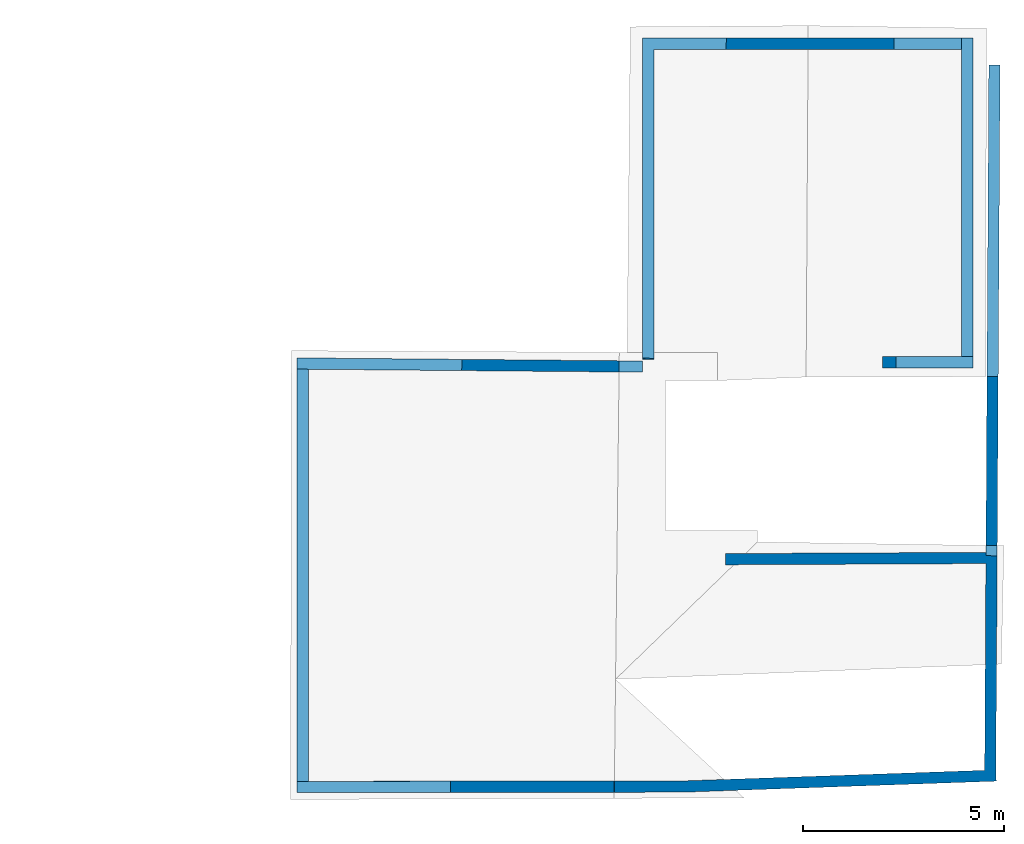
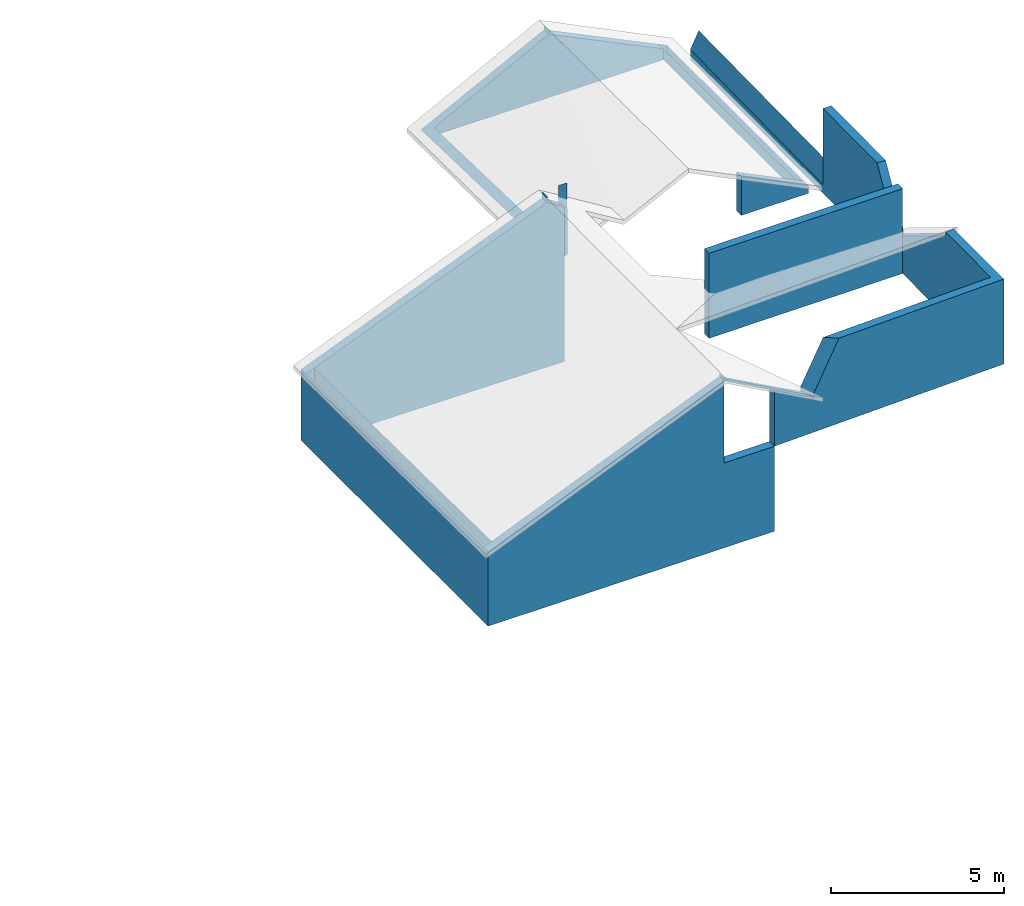
# One storey, part 4 of 4: 1 wall.
"""IFC4 building model written with IfcOpenShell, lengths in metres."""

from ifc_helpers import new_model, entity, si_unit, converted_unit, frame, frame_2d, origin_with_axes, place, context, subcontext, project, spatial, polygons, element, save


model = new_model("IFC4")

# Units and contexts
model_context = context("Model", 3, precision=1e-05, world=origin_with_axes())
plan_context = context("Plan", 2, precision=1e-05, world=frame_2d((0.0, 0.0, 0.0), x_axis=(1.0, 0.0, 0.0)))
body_context = subcontext(model_context, "Body", "Model", "MODEL_VIEW")
ifc_project = project(units=[converted_unit("PLANEANGLEUNIT", "degree", entity("IfcReal", 0.0174532925199433), si_unit("PLANEANGLEUNIT", "RADIAN"), dimensions=[0, 0, 0, 0, 0, 0, 0]), si_unit("AREAUNIT", "SQUARE_METRE"), si_unit("VOLUMEUNIT", "CUBIC_METRE"), si_unit("LENGTHUNIT", "METRE")], contexts=[model_context, plan_context])

# Site, building, storey
site_placement = place(None, origin_with_axes())
site = spatial("IfcSite", under=ifc_project, at=site_placement)
building_placement = place(site_placement, origin_with_axes())
building = spatial("IfcBuilding", under=site, at=building_placement, Name="Building")
storey_placement = place(building_placement, frame((0.0, 0.0, 3.0), z_axis=(0.0, 0.0, 1.0), x_axis=(1.0, 0.0, 0.0)))
storey = spatial("IfcBuildingStorey", under=building, at=storey_placement, Name="Dachgeschoss")

# Wall
wall_placement = place(storey_placement, frame((217.804901123047, 19.0355453491211, -2.38418579989741e-07), z_axis=(0.0, 0.0, 1.0), x_axis=(-0.00592900207266212, -0.999982416629791, 0.0)))
element("IfcWall", 1, at=wall_placement, inside=storey, Name="Wall", PredefinedType="ELEMENTEDWALL", context=body_context, shape_type="Tessellation", body=[
    polygons([(0.0, 0.280000001192093, 0.0), (17.5594806671143, 0.280000001192093, 3.0), (17.5594806671143, 0.280000001192093, 0.0), (0.00166013569105417, 0.0, 0.0), (17.5594806671143, 0.0, 3.0), (17.5594806671143, 0.0, 0.0), (12.1345434188843, 7.62939453125e-06, 0.0), (12.1345434188843, 7.62939453125e-06, 3.0), (12.4145278930664, 0.00297598727047443, 3.0), (12.4145278930664, 0.00297598727047443, 0.0), (12.4832715988159, -6.4811224937439, 3.0), (12.4832715988159, -6.4811224937439, 0.0), (12.2032871246338, -6.48409080505371, 3.0), (12.2032871246338, -6.48409080505371, 0.0), (7.55921268463135, -2.6036376953125, 0.0), (7.27921772003174, -2.60529780387878, 0.0), (7.26588344573975, -0.356342554092407, 0.0), (7.54587841033936, -0.354682445526123, 0.0), (-0.661626815795898, -0.683349609375, 0.0), (-0.663286864757538, -0.403354525566101, 0.0), (7.26588487625122, -0.356342911720276, 0.0), (7.26754474639893, -0.636337995529175, 0.0), (18.1491012573242, -7.52742004394531, 0.0), (17.8693370819092, -7.53891849517822, 0.0), (17.8063201904297, -6.00570869445801, 0.0), (18.0860843658447, -5.99420976638794, 0.0), (7.42261981964111, -8.56973266601562, 0.0), (7.70261859893799, -8.57056045532227, 0.0), (7.70088958740234, -9.15579032897949, 3.0), (7.70088958740234, -9.15579032897949, 0.0), (7.42089033126831, -9.15496253967285, 3.0), (7.42089033126831, -9.15496253967285, 0.0), (18.0860862731934, -5.99420928955078, 0.0), (17.8063220977783, -6.00570774078369, 0.0), (17.5479736328125, 0.280002593994141, 3.0), (17.5479736328125, 0.280002593994141, 0.0), (17.8277378082275, 0.291501045227051, 3.0), (17.8277378082275, 0.291501045227051, 0.0), (7.39721012115479, -17.1688270568848, -2.99999976158142), (7.42261171340942, -8.57221508026123, -2.99999976158142), (7.42261171340942, -8.57221508026123, 2.38418579101562e-07), (7.70261812210083, -8.57055473327637, -2.99999976158142), (7.67721652984619, -17.1671676635742, -2.99999976158142), (7.70261812210083, -8.57055473327637, 2.38418579101562e-07), (17.9347324371338, -17.1063613891602, -2.99999976158142), (7.67721366882324, -17.167179107666, -2.99999976158142), (7.67804050445557, -16.8871688842773, -2.99999976158142), (17.9328136444092, -16.8263683319092, -2.99999976158142), (7.42088985443115, -9.15496063232422, -0.0010530948638916), (7.42088985443115, -9.15496063232422, 2.99894690513611), (7.70088863372803, -9.15578842163086, 2.99894690513611), (7.70088863372803, -9.15578842163086, -0.0010530948638916), (18.1491012573242, -7.52743148803711, -2.99999976158142), (18.214729309082, -17.1046981811523, -2.99999976158142), (18.1491012573242, -7.52743148803711, 2.38418579101562e-07), (17.9347343444824, -17.1063575744629, -2.99999976158142), (17.869140625, -7.53413963317871, -2.99999976158142), (17.869140625, -7.53413963317871, 2.38418579101562e-07), (17.8815288543701, -9.21857070922852, 0.0), (18.1615219116211, -9.21665191650391, 0.0), (-0.381631433963776, -0.68168830871582, 0.0), (-0.661626517772675, -0.683348655700684, 0.0), (-0.336235046386719, -8.33821868896484, 0.0), (-0.616230130195618, -8.33987903594971, 0.0), (7.75790739059448, 0.0, 3.0), (7.7554178237915, 0.280000030994415, 3.0), (7.7589545249939, 0.280000001192093, 0.882091522216797), (7.76240062713623, -1.86264514923096e-09, 0.30917689204216), (0.00166013569105417, 0.0, 0.358669877052307), (0.0, 0.280000001192093, 0.931573152542114), (11.9644355773926, 0.279999703168869, 1.19363474845886), (11.9618701934814, -1.49011611938477e-07, 1.19479942321777), (10.9232635498047, 0.0, 3.0), (10.9251594543457, 0.280000001192093, 3.0), (11.9644365310669, 0.279999345541, 1.04363465309143), (11.9618701934814, -1.78813934326172e-07, 1.04479956626892), (12.4145278930664, 0.00297598727047443, 1.32514071464539), (12.1345434188843, 7.62939453125e-06, 1.15175127983093), (14.9322729110718, 0.0, 3.0), (14.9196262359619, 0.280000656843185, 2.86951446533203), (14.9196281433105, 0.280000001192093, 3.0), (14.9322719573975, 4.76837158203125e-07, 2.86966133117676), (12.4810476303101, -6.27136373519897, 1.36857640743256), (12.1979665756226, -5.98224020004272, 1.21987020969391), (7.55921268463135, -2.6036376953125, 1.36820566654205), (7.54587841033936, -0.354682445526123, 0.26000314950943), (7.29012489318848, -0.356198817491531, 0.259734660387039), (7.26588344573975, -0.356342554092407, 0.259709000587463), (7.27921772003174, -2.60529780387878, 1.36791121959686), (7.26588487625122, -0.356342911720276, 0.259709000587463), (7.26754474639893, -0.636337995529175, 0.397680401802063), (-0.663286864757538, -0.403354525566101, 0.249662518501282), (-0.661626815795898, -0.683349609375, 0.385395258665085), (-0.381631433963776, -0.68168830871582, 0.386846214532852), (-0.36673840880394, -3.19353914260864, 1.60451352596283), (-0.358984053134918, -4.50138807296753, 2.23851776123047), (-0.661626517772675, -0.683348655700684, 0.385394871234894), (-0.638989090919495, -4.50137090682983, 2.23625326156616), (18.0589237213135, -5.33337497711182, 3.0), (17.7942562103271, -5.71210670471191, 3.0), (12.4810476303101, -6.2713680267334, 1.51857709884644), (12.4748783111572, -5.68941354751587, 3.0), (12.1911773681641, -5.34187078475952, 3.0), (12.1979675292969, -5.98224449157715, 1.36987054347992), (-0.638993859291077, -4.50056409835815, 2.38790512084961), (-0.434731930494308, -4.50138330459595, 2.38790512084961), (-0.638988554477692, -4.50137138366699, 2.38625311851501), (18.1491012573242, -7.52742862701416, 1.96492123603821), (18.1606636047363, -9.21478748321533, 2.89666795730591), (18.0941562652588, -6.19061231613159, 1.22652006149292), (17.8691082000732, -7.52934741973877, 1.96462726593018), (18.1491012573242, -7.52742004394531, 1.96491670608521), (17.8693370819092, -7.53891849517822, 1.96991300582886), (17.8259944915771, -6.48437881469727, 1.38742971420288), (17.8806476593018, -9.21324157714844, 2.89446043968201), (18.0941562652588, -6.19061183929443, 1.37652015686035), (17.8259925842285, -6.48437929153442, 1.53743004798889), (18.0860843658447, -5.99420976638794, 1.74847817420959), (18.0860862731934, -5.99420928955078, 1.74847412109375), (17.8063220977783, -6.00570774078369, 2.44396114349365), (17.8063201904297, -6.00570869445801, 2.44396424293518), (12.4810476303101, -6.2713623046875, 1.51857602596283), (12.4832715988159, -6.48112201690674, 1.97042119503021), (12.1979665756226, -5.98223876953125, 1.36986982822418), (12.2032871246338, -6.48409080505371, 2.4509117603302), (12.4810476303101, -6.2713680267334, 1.36857652664185), (12.4832715988159, -6.4811224937439, 1.46438932418823), (12.1979675292969, -5.98224449157715, 1.21987009048462), (12.2032871246338, -6.48409080505371, 1.44910597801208), (7.70095157623291, -9.13480281829834, 3.0), (7.70088911056519, -9.15578937530518, 2.96623420715332), (7.42095851898193, -9.13188457489014, 3.0), (7.42089033126831, -9.15496253967285, 2.96287202835083), (7.42088985443115, -9.15496063232422, 2.96287512779236), (7.42088842391968, -9.1555004119873, 2.96200680732727), (7.70088863372803, -9.15578842163086, 2.96623730659485), (7.70088624954224, -9.15704536437988, 2.96421408653259), (-0.434496968984604, -4.50138473510742, 2.38790512084961), (-0.358984023332596, -4.501389503479, 2.38790512084961), (-0.638989329338074, -4.50137233734131, 2.38625121116638), (-0.358984053134918, -4.501389503479, 2.23851561546326), (-0.63898903131485, -4.50137233734131, 2.23625087738037), (-0.358984023332596, -4.50138854980469, 2.38790512084961), (-0.638984203338623, -4.50218725204468, 2.38790512084961), (-0.614570677280426, -8.619873046875, 0.13964319229126), (-0.616230666637421, -8.33987808227539, 0.28252100944519), (-0.336235016584396, -8.33821868896484, 0.290164321660995), (-0.616230130195618, -8.33987903594971, 0.282520443201065), (7.20485877990723, -8.29350757598877, 2.43013834953308), (18.2084465026855, -16.1878490447998, 2.38418579101562e-07), (18.214729309082, -17.1046981811523, -0.380925297737122), (17.9284057617188, -16.182975769043, 2.38418579101562e-07), (17.9347343444824, -17.1063575744629, -0.383638441562653), (18.2092933654785, -16.1878623962402, 0.0), (17.9292526245117, -16.1829929351807, 0.0), (9.27590274810791, -17.1576995849609, -0.467565834522247), (17.9347324371338, -17.1063613891602, -0.383640229701996), (17.9328136444092, -16.8263683319092, -0.267310857772827), (7.67721366882324, -17.167179107666, -0.48306131362915), (7.67721652984619, -17.1671676635742, -0.483056485652924), (7.42084312438965, -9.17076969146729, 2.99894690513611), (7.42088842391968, -9.15549468994141, 2.96200823783875), (7.70084238052368, -9.17140197753906, 2.99894690513611), (7.70088529586792, -9.1570405960083, 2.96421551704407), (18.1606636047363, -9.21478748321533, 3.0), (17.8806476593018, -9.21324157714844, 3.0), (7.42088794708252, -9.15549373626709, 2.81200814247131), (7.70088481903076, -9.1570405960083, 2.81421542167664), (7.7008900642395, -9.15579032897949, 2.81343030929565), (7.42089033126831, -9.15496253967285, 2.81167078018188), (7.42088985443115, -9.15496063232422, 2.81166934967041), (7.42088842391968, -9.1555004119873, 2.81200623512268), (7.70088863372803, -9.15578842163086, 2.81342887878418), (7.70088481903076, -9.1570463180542, 2.814213514328), (17.8815288543701, -9.21857070922852, 2.8922758102417), (18.1615219116211, -9.21665191650391, 2.89590835571289), (7.67804050445557, -16.8871688842773, -0.36707615852356), (7.68067932128906, -15.9952211380005, 2.38418579101562e-07), (7.4006986618042, -15.9883127212524, 2.38418579101562e-07), (7.39721012115479, -17.1688270568848, -0.485834538936615), (7.40069103240967, -15.9908723831177, -0.0010530948638916), (7.68067169189453, -15.9977807998657, -0.0010530948638916), (7.42088842391968, -9.1555004119873, 2.96200680732727), (7.70088624954224, -9.15704536437988, 2.96421408653259), (7.70510768890381, -8.57054615020752, 2.44963526725769), (7.70261859893799, -8.57056045532227, 2.44963479042053), (7.42261981964111, -8.56973266601562, 2.44927215576172), (7.38854074478149, -8.57242298126221, 0.365927577018738), (7.38946437835693, -8.29241275787354, 0.507701098918915), (7.38854026794434, -8.57242298126221, 0.515927672386169), (7.38946342468262, -8.29241275787354, 0.657701075077057), (7.35194158554077, -8.57263946533203, 3.0), (7.35495328903198, -8.29261684417725, 3.0), (7.20485877990723, -8.29350757598877, 2.43013834953308)], [[[1, 3, 6, 4]], [[2, 5, 6, 3]], [[5, 79, 82, 76, 72, 73, 65, 68, 69, 4, 6]], [[2, 81, 79, 5]], [[11, 13, 125, 123]], [[124, 125, 103]], [[8, 103, 102, 9]], [[8, 9, 77, 78]], [[14, 7, 10, 12]], [[9, 102, 11, 123, 122, 83, 77]], [[18, 15, 16, 17]], [[22, 19, 20, 21]], [[26, 23, 24, 25]], [[31, 131, 29]], [[31, 132, 133]], [[32, 27, 28, 30]], [[35, 37, 38, 36]], [[119, 33, 38]], [[38, 33, 34, 36]], [[39, 43, 160, 180]], [[42, 43, 39, 40]], [[44, 178, 160, 43, 42]], [[41, 44, 42, 40]], [[48, 177, 158]], [[47, 48, 45, 46]], [[45, 48, 158, 157]], [[50, 161, 163, 51]], [[50, 51, 136, 134]], [[168, 52, 174]], [[56, 57, 53, 54]], [[58, 152, 150, 55]], [[53, 57, 58, 55]], [[55, 150, 151, 54, 53]], [[54, 153, 56]], [[60, 154, 155, 59]], [[64, 62, 61, 63]], [[62, 97, 94, 61]], [[64, 148, 142, 140, 144, 105, 107, 98, 97, 62]], [[170, 187, 27, 32]], [[143, 106, 105, 144, 138, 139]], [[152, 57, 56]], [[68, 67, 70, 69]], [[115, 109, 108, 111]], [[110, 114, 113, 112]], [[80, 82, 79, 81]], [[70, 67, 66, 74, 71, 75, 80, 81, 2, 3, 1]], [[179, 178, 44, 41]], [[191, 190, 192, 193]], [[155, 175, 59]], [[84, 77, 78]], [[80, 76, 82]], [[124, 122, 83, 84]], [[106, 107, 105]], [[93, 92, 20, 19]], [[139, 141, 147, 63, 61, 94, 95, 96, 143]], [[104, 101, 102, 103]], [[159, 177, 47, 46]], [[84, 14, 129]], [[186, 169, 30, 28]], [[131, 130, 29]], [[156, 46, 45]], [[85, 89, 16, 15]], [[171, 173, 52, 49]], [[77, 83, 122, 123, 127, 12, 10]], [[138, 140, 142, 141, 139]], [[107, 106, 143, 96, 98]], [[162, 50, 183]], [[88, 87, 86, 18, 17]], [[86, 85, 15, 18]], [[114, 121, 25]], [[72, 74, 73]], [[117, 116, 118, 121]], [[100, 120, 119, 99]], [[89, 88, 17, 16]], [[128, 126, 101, 104]], [[176, 154, 60]], [[100, 99, 37, 35]], [[147, 148, 64, 63]], [[109, 115, 166, 165]], [[182, 181, 49, 52]], [[110, 23, 26]], [[71, 76, 75]], [[123, 125, 129, 127]], [[127, 129, 14, 12]], [[187, 186, 28, 27]], [[130, 132, 31, 29]], [[180, 179, 41, 40, 39]], [[92, 90, 21, 20]], [[169, 170, 32, 30]], [[102, 103, 13, 11]], [[176, 155, 154]], [[168, 167, 181, 182]], [[180, 178, 179]], [[152, 153, 151, 150]], [[78, 77, 10, 7]], [[140, 138, 144]], [[112, 113, 24, 23]], [[119, 120, 34, 33]], [[162, 168, 164]], [[188, 146, 145]], [[142, 147, 141]], [[162, 164, 163, 161]], [[121, 118, 26, 25]], [[100, 36, 34]], [[132, 130, 131, 133]], [[175, 176, 60, 59]], [[190, 191, 189, 188]], [[116, 114, 110]], [[91, 93, 19, 22]], [[97, 98, 96, 95, 94]], [[85, 86, 87]], [[126, 128, 129, 127]], [[90, 91, 22, 21]], [[67, 68, 65, 66]], [[73, 74, 66, 65]], [[122, 124, 125, 123]], [[69, 70, 1, 4]], [[125, 13, 103]], [[103, 8, 78]], [[78, 84, 103]], [[84, 124, 103]], [[31, 133, 131]], [[38, 37, 99]], [[99, 119, 38]], [[48, 47, 177]], [[136, 51, 163]], [[136, 163, 164]], [[174, 184, 137]], [[137, 136, 164]], [[168, 182, 52]], [[137, 164, 168]], [[52, 173, 174]], [[137, 168, 174]], [[54, 151, 153]], [[56, 153, 152]], [[152, 58, 57]], [[84, 83, 77]], [[80, 75, 76]], [[129, 125, 124]], [[84, 78, 7]], [[129, 124, 84]], [[84, 7, 14]], [[45, 157, 156]], [[156, 159, 46]], [[49, 181, 167]], [[162, 161, 50]], [[49, 167, 172]], [[167, 162, 172]], [[172, 171, 49]], [[134, 135, 183]], [[50, 134, 183]], [[172, 162, 183]], [[24, 113, 114]], [[114, 117, 121]], [[25, 24, 114]], [[72, 71, 74]], [[26, 118, 110]], [[118, 116, 110]], [[110, 112, 23]], [[71, 72, 76]], [[176, 175, 155]], [[180, 160, 178]], [[162, 167, 168]], [[188, 189, 146]], [[142, 148, 147]], [[34, 120, 100]], [[100, 35, 36]], [[116, 117, 114]], [[87, 88, 89]], [[89, 85, 87]]]),
])

save(model, "model.ifc")
